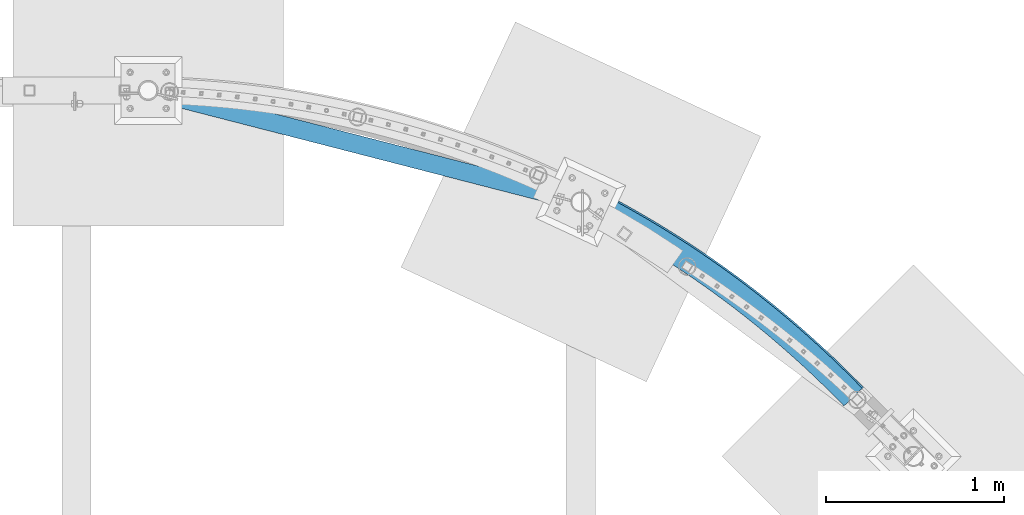
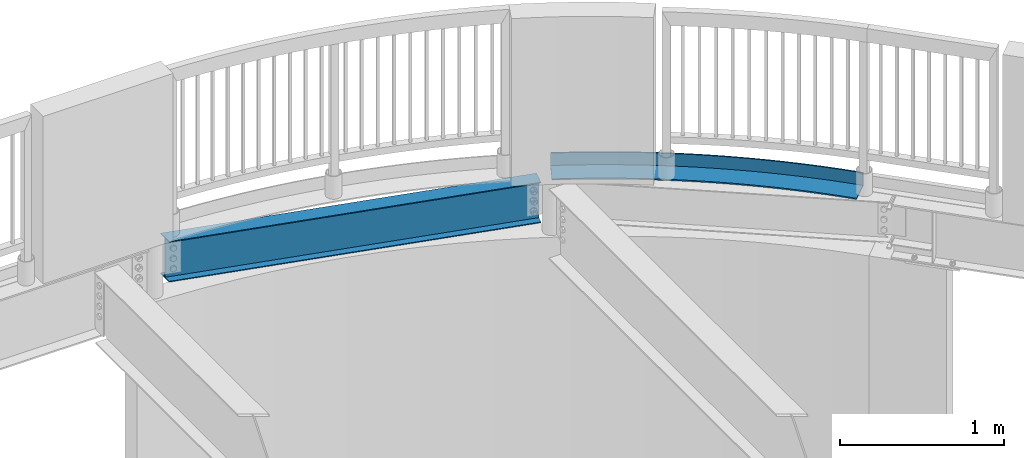
# One storey, part 329 of 975: 2 beams.
"""IFC2X3 building model written with IfcOpenShell, lengths in millimetres."""

from ifc_helpers import new_model, si_unit, frame, origin_with_axes, place, context, subcontext, project, spatial, faceted_brep, material, type_object, element, save


model = new_model("IFC2X3")

# Units and contexts
model_context = context("Model", 3, precision=1e-05, world=origin_with_axes())
body_context = subcontext(model_context, "Body", "Model", "MODEL_VIEW")
ifc_project = project(units=[si_unit("LENGTHUNIT", "METRE", prefix="MILLI"), si_unit("AREAUNIT", "SQUARE_METRE"), si_unit("VOLUMEUNIT", "CUBIC_METRE"), si_unit("MASSUNIT", "GRAM", prefix="KILO"), si_unit("TIMEUNIT", "SECOND"), si_unit("PLANEANGLEUNIT", "RADIAN"), si_unit("SOLIDANGLEUNIT", "STERADIAN"), si_unit("THERMODYNAMICTEMPERATUREUNIT", "DEGREE_CELSIUS"), si_unit("LUMINOUSINTENSITYUNIT", "LUMEN")], contexts=[model_context])

# Site, building, storey
site_placement = place(None, origin_with_axes())
site = spatial("IfcSite", under=ifc_project, at=site_placement, CompositionType="ELEMENT")
building_placement = place(site_placement, origin_with_axes())
building = spatial("IfcBuilding", under=site, at=building_placement, Name="Undefined", CompositionType="ELEMENT")
storey_placement = place(building_placement, origin_with_axes())
storey = spatial("IfcBuildingStorey", under=building, at=storey_placement, Name="Undefined", CompositionType="ELEMENT", Elevation=0.0)

# Beams
ifc_material_1 = material(Name="STEEL/A36")
beam_type_1 = type_object("IfcBeamType", Name="L6X4X3/8", PredefinedType="NOTDEFINED")
beam_1_placement = place(storey_placement, frame((20394.9391739001, 28239.6693829662, 3987.8), z_axis=(-0.592160376867189, -0.805820133819271, 0.0), x_axis=(-0.805820133819271, 0.592160376867189, 0.0)))
element("IfcBeam", 1, at=beam_1_placement, inside=storey, type_object=beam_type_1, material=ifc_material_1, Name="ANGLE", ObjectType="L6X4X3/8", context=body_context, shape_type="Brep", body=[
    faceted_brep([(12.7670494130856, 50.8000000000002, 75.1228490493304), (12.7670494130856, 41.2750000000001, 75.1228490493304), (44.1095823313375, 41.2750000000001, 69.8881844457283), (44.1095823313375, 50.8000000000002, 69.8881844457283), (-11.171168236449, 41.2750000000001, -65.7324929181559), (-11.171168236449, -50.8000000000002, -65.7324929181559), (20.9755353170134, -50.8000000000002, -71.1014658614949), (20.9755353170134, 41.2750000000001, -71.1014658614949), (-12.7670494130886, -50.8000000000002, -75.1228490493231), (-12.7670494130886, 50.8000000000002, -75.1228490493231), (19.4332655160564, 50.8000000000002, -80.5007758819775), (19.4332655160564, -50.8000000000002, -80.5007758819775), (75.481476174013, 41.2750000000001, 64.8324589816693), (75.481476174013, 50.8000000000002, 64.8324589816693), (53.1523531224396, -50.8000000000002, -76.286908536611), (53.1523531224396, 41.2750000000001, -76.286908536611), (51.6637449190006, 50.8000000000002, -85.6948663711664), (51.6637449190006, -50.8000000000002, -85.6948663711664), (106.881709359738, 41.2750000000001, 59.95583728973), (106.881709359738, 50.8000000000002, 59.95583728973), (85.3582373872399, -50.8000000000002, -81.2886520868924), (85.3582373872399, 41.2750000000001, -81.2886520868924), (83.923339255742, 50.8000000000002, -90.7049513786696), (83.923339255742, -50.8000000000002, -90.7049513786696), (138.309259384294, 41.2750000000001, 55.2584781701808), (138.309259384294, 50.8000000000002, 55.2584781701808), (117.592139372321, -50.8000000000002, -86.1065336376269), (117.592139372321, 41.2750000000001, -86.1065336376269), (116.210998038189, 50.8000000000002, -95.5308677581488), (116.210998038189, -50.8000000000002, -95.5308677581488), (169.763102853944, 41.2750000000001, 50.7405345859006), (169.763102853944, 50.8000000000002, 50.7405345859006), (149.853009426219, -50.8000000000002, -90.740396301313), (149.853009426219, 41.2750000000001, -90.740396301313), (148.52566986437, 50.8000000000002, -100.172458360466), (148.52566986437, -50.8000000000002, -100.172458360466), (201.242215518733, 41.2750000000001, 46.40215365732), (201.242215518733, 50.8000000000002, 46.40215365732), (182.139797019309, -50.8000000000002, -95.1900891827681), (182.139797019309, 41.2750000000001, -95.1900891827681), (180.866302452685, 50.8000000000002, -104.629572038779), (180.866302452685, -50.8000000000002, -104.629572038779), (232.745572305856, 41.2750000000001, 42.2434766576844), (232.745572305856, 50.8000000000002, 42.2434766576844), (214.451450777988, -50.8000000000002, -99.4554673840248), (214.451450777988, 41.2750000000001, -99.4554673840248), (213.231842676131, 50.8000000000002, -108.902063653477), (213.231842676131, -50.8000000000002, -108.902063653477), (264.272147353028, 41.2750000000001, 38.264639008441), (264.272147353028, 50.8000000000002, 38.264639008441), (246.786918518923, -50.8000000000002, -103.536392009082), (246.786918518923, 41.2750000000001, -103.536392009082), (245.621236596652, 50.8000000000002, -112.989794076922), (245.621236596652, -50.8000000000002, -112.989794076922), (295.820914041897, 41.2750000000001, 34.4657702748082), (295.820914041897, 50.8000000000002, 34.4657702748082), (279.14514728332, -50.8000000000002, -107.432730168388), (279.14514728332, 41.2750000000001, -107.432730168388), (278.033429499414, 50.8000000000002, -116.89263019793), (278.033429499414, -50.8000000000002, -116.89263019793), (327.390845031467, 41.2750000000001, 30.8469941615695), (327.390845031467, 50.8000000000002, 30.8469941615695), (311.525083371191, -50.8000000000002, -111.144354983197), (311.525083371191, 41.2750000000001, -111.144354983197), (310.467365927174, 50.8000000000002, -120.610444926184), (310.467365927174, -50.8000000000002, -120.610444926184), (358.980912291565, 41.2750000000001, 27.4084285090721), (358.980912291565, 50.8000000000002, 27.4084285090721), (343.925672375688, -50.8000000000002, -114.671145589702), (343.925672375688, 41.2750000000001, -114.671145589702), (342.921989714631, 50.8000000000002, -124.14311719629), (342.921989714631, -50.8000000000002, -124.14311719629), (390.590087136296, 41.2750000000001, 24.1501852893271), (390.590087136296, 50.8000000000002, 24.1501852893271), (376.345859217431, -50.8000000000002, -118.012987142953), (376.345859217431, 41.2750000000001, -118.012987142953), (375.396244022843, 50.8000000000002, -127.490531971765), (375.396244022843, -50.8000000000002, -127.490531971765), (422.217340257574, 41.2750000000001, 21.0723706024291), (422.217340257574, 50.8000000000002, 21.0723706024291), (408.784588178866, -50.8000000000002, -121.16977082059), (408.784588178866, 41.2750000000001, -121.16977082059), (407.889071373613, 50.8000000000002, -130.652580248789), (407.889071373613, -50.8000000000002, -130.652580248789), (453.861641758597, 41.2750000000001, 18.1750846730574), (453.861641758597, 50.8000000000002, 18.1750846730574), (441.240802938625, -50.8000000000002, -124.141393826423), (441.240802938625, 41.2750000000001, -124.141393826423), (440.399413683958, 50.8000000000002, -133.629159059725), (440.399413683958, -50.8000000000002, -133.629159059725), (485.521961187415, 41.2750000000001, 15.4584218472373), (485.521961187415, 50.8000000000002, 15.4584218472373), (473.713446605962, -50.8000000000002, -126.927759393751), (473.713446605962, 41.2750000000001, -126.927759393751), (472.926212300529, 50.8000000000002, -136.420171476486), (472.926212300529, -50.8000000000002, -136.420171476486), (517.19726757048, 41.2750000000001, 12.9224705892557), (517.19726757048, 50.8000000000002, 12.9224705892557), (506.201461755131, -50.8000000000002, -129.528776788524), (506.201461755131, 41.2750000000001, -129.528776788524), (505.468408034107, 50.8000000000002, -139.025526613703), (505.468408034107, -50.8000000000002, -139.025526613703), (548.886529446218, 41.2750000000001, 10.5673134787794), (548.886529446218, 50.8000000000002, 10.5673134787794), (538.703790459842, -50.8000000000002, -131.944361312264), (538.703790459842, 41.2750000000001, -131.944361312264), (538.024941194084, 50.8000000000002, -141.445139631673), (538.024941194084, -50.8000000000002, -141.445139631673), (580.588714898601, 41.2750000000001, 8.3930272081634), (580.588714898601, 50.8000000000002, 8.3930272081634), (571.219374327708, -50.8000000000002, -134.174434304899), (571.219374327708, 41.2750000000001, -134.174434304899), (570.594751622979, 50.8000000000002, -143.678931739109), (570.594751622979, -50.8000000000002, -143.678931739109), (612.302791590779, 41.2750000000001, 6.3996825799768), (612.302791590779, 50.8000000000002, 6.3996825799768), (603.747154534695, -50.8000000000002, -136.218923147251), (603.747154534695, 41.2750000000001, -136.218923147251), (603.176778730951, 50.8000000000002, -145.72683019573), (603.176778730951, -50.8000000000002, -145.72683019573), (644.027726798668, 41.2750000000001, 4.58734450466), (644.027726798668, 50.8000000000002, 4.58734450466), (636.286071859619, -50.8000000000002, -138.077761263419), (636.286071859619, 41.2750000000001, -138.077761263419), (635.76996153035, 50.8000000000002, -147.588768314621), (635.76996153035, -50.8000000000002, -147.588768314621), (675.7624874446, 41.2750000000001, 2.95607199845108), (675.7624874446, 50.8000000000002, 2.95607199845108), (668.835066718635, -50.8000000000002, -139.750888122973), (668.835066718635, 41.2750000000001, -139.750888122973), (668.373238670242, 50.8000000000002, -149.264685464404), (668.373238670242, -50.8000000000002, -149.264685464404), (707.50604013095, 41.2750000000001, 1.50591818142129), (707.50604013095, 50.8000000000002, 1.50591818142129), (701.393079199736, -50.8000000000002, -141.23824924291), (701.393079199736, 41.2750000000001, -141.23824924291), (700.985548470992, 50.8000000000002, -150.7545270712), (700.985548470992, -50.8000000000002, -150.7545270712), (739.25735117379, 41.2750000000001, 0.236930275794293), (739.25735117379, 50.8000000000002, 0.236930275794293), (733.959049097266, -50.8000000000002, -142.539796189405), (733.959049097266, 41.2750000000001, -142.539796189405), (733.605828958831, 50.8000000000002, -152.058244620421), (733.605828958831, -50.8000000000002, -152.058244620421), (771.015386636566, 41.2750000000001, -0.850850395640009), (771.015386636566, 50.8000000000002, -0.850850395640009), (766.531915946442, -50.8000000000002, -143.655486579424), (766.531915946442, 41.2750000000001, -143.655486579424), (766.233017900433, 50.8000000000002, -153.175795658346), (766.233017900433, -50.8000000000002, -153.175795658346), (802.77911236374, 41.2750000000001, -1.75738841084967), (802.77911236374, 50.8000000000002, -1.75738841084967), (799.110619057902, -50.8000000000002, -144.585284082095), (799.110619057902, 41.2750000000001, -144.585284082095), (798.866052837512, 50.8000000000002, -154.107143793517), (798.866052837512, -50.8000000000002, -154.107143793517), (834.547494014478, 41.2750000000001, -2.48265424968849), (834.547494014478, 50.8000000000002, -2.48265424968849), (831.694097552225, -50.8000000000002, -145.329158419874), (831.694097552225, 41.2750000000001, -145.329158419874), (831.50387112141, 50.8000000000002, -154.852258697887), (831.50387112141, -50.8000000000002, -154.852258697887), (866.319497096344, 41.2750000000001, -3.02662429491465), (866.319497096344, 50.8000000000002, -3.02662429491465), (864.281290394493, -50.8000000000002, -145.887085369533), (864.281290394493, 41.2750000000001, -145.887085369533), (864.145409947704, 50.8000000000002, -155.411116107847), (864.145409947704, -50.8000000000002, -155.411116107847), (898.094086998959, 41.2750000000001, -3.38928083289647), (898.094086998959, 50.8000000000002, -3.38928083289647), (896.871136428841, -50.8000000000002, -146.259046762985), (896.871136428841, 41.2750000000001, -146.259046762985), (896.789606390832, 50.8000000000002, -155.783697824991), (896.789606390832, -50.8000000000002, -155.783697824991), (929.870229027725, 41.2750000000001, -3.57061205425998), (929.870229027725, 50.8000000000002, -3.57061205425998), (929.46257441299, -50.8000000000002, -146.445030487819), (929.46257441299, 41.2750000000001, -146.445030487819), (929.435397438676, 50.8000000000002, -155.969991716724), (929.435397438676, -50.8000000000002, -155.969991716724), (961.646888437488, 41.2750000000001, -3.5706120541945), (961.646888437488, 50.8000000000002, -3.5706120541945), (962.054543052835, -50.8000000000002, -146.445030487754), (962.054543052835, 41.2750000000001, -146.445030487754), (962.081720027191, 50.8000000000002, -155.969991716658), (962.081720027191, -50.8000000000002, -155.969991716658), (993.423030466247, 41.2750000000001, -3.38928083269275), (993.423030466247, 50.8000000000002, -3.38928083269275), (994.645981036984, -50.8000000000002, -146.259046762767), (994.645981036984, 41.2750000000001, -146.259046762767), (994.727511075035, 50.8000000000002, -155.78369782478), (994.727511075035, -50.8000000000002, -155.78369782478), (1025.19762036887, 41.2750000000001, -3.02662429457268), (1025.19762036887, 50.8000000000002, -3.02662429457268), (1027.23582707133, -50.8000000000002, -145.887085369184), (1027.23582707133, 41.2750000000001, -145.887085369184), (1027.37170751816, 50.8000000000002, -155.411116107491), (1027.37170751816, -50.8000000000002, -155.411116107491), (1056.96962345073, 41.2750000000001, -2.48265424920828), (1056.96962345073, 50.8000000000002, -2.48265424920828), (1059.82301991359, -50.8000000000002, -145.329158419379), (1059.82301991359, 41.2750000000001, -145.329158419379), (1060.01324634446, 50.8000000000002, -154.852258697392), (1060.01324634446, -50.8000000000002, -154.852258697392), (1088.73800510146, 41.2750000000001, -1.75738841022394), (1088.73800510146, 50.8000000000002, -1.75738841022394), (1092.40649840792, -50.8000000000002, -144.58528408147), (1092.40649840792, 41.2750000000001, -144.58528408147), (1092.65106462835, 50.8000000000002, -154.107143792884), (1092.65106462835, -50.8000000000002, -154.107143792884), (1120.50173082863, 41.2750000000001, -0.850850394890585), (1120.50173082863, 50.8000000000002, -0.850850394890585), (1124.98520151937, -50.8000000000002, -143.655486578653), (1124.98520151937, 41.2750000000001, -143.655486578653), (1125.28409956542, 50.8000000000002, -153.175795657575), (1125.28409956542, -50.8000000000002, -153.175795657575), (1152.2597662914, 41.2750000000001, 0.23693027668196), (1152.2597662914, 50.8000000000002, 0.23693027668196), (1157.55806836854, -50.8000000000002, -142.539796188496), (1157.55806836854, 41.2750000000001, -142.539796188496), (1157.91128850702, 50.8000000000002, -152.058244619504), (1157.91128850702, -50.8000000000002, -152.058244619504), (1184.01107733424, 41.2750000000001, 1.50591818245448), (1184.01107733424, 50.8000000000002, 1.50591818245448), (1190.12403826606, -50.8000000000002, -141.238249241862), (1190.12403826606, 41.2750000000001, -141.238249241862), (1190.53156899486, 50.8000000000002, -150.754527070145), (1190.53156899486, -50.8000000000002, -150.754527070145), (1215.75463002058, 41.2750000000001, 2.95607199961523), (1215.75463002058, 50.8000000000002, 2.95607199961523), (1222.68205074716, -50.8000000000002, -139.750888121787), (1222.68205074716, 41.2750000000001, -139.750888121787), (1223.14387879559, 50.8000000000002, -149.264685463211), (1223.14387879559, -50.8000000000002, -149.264685463211), (1247.4893906665, 41.2750000000001, 4.58734450596239), (1247.4893906665, 50.8000000000002, 4.58734450596239), (1255.23104560617, -50.8000000000002, -138.07776126208), (1255.23104560617, 41.2750000000001, -138.07776126208), (1255.74715593548, 50.8000000000002, -147.58876831329), (1255.74715593548, -50.8000000000002, -147.58876831329), (1279.21432587439, 41.2750000000001, 6.39968258141744), (1279.21432587439, 50.8000000000002, 6.39968258141744), (1287.76996293109, -50.8000000000002, -136.218923145774), (1287.76996293109, 41.2750000000001, -136.218923145774), (1288.34033873487, 50.8000000000002, -145.72683019426), (1288.34033873487, -50.8000000000002, -145.72683019426), (1310.92840256655, 41.2750000000001, 8.39302720974229), (1310.92840256655, 50.8000000000002, 8.39302720974229), (1320.29774313806, -50.8000000000002, -134.174434303291), (1320.29774313806, 41.2750000000001, -134.174434303291), (1320.92236584284, 50.8000000000002, -143.678931737486), (1320.92236584284, -50.8000000000002, -143.678931737486), (1342.63058801893, 41.2750000000001, 10.5673134804892), (1342.63058801893, 50.8000000000002, 10.5673134804892), (1352.81332700592, -50.8000000000002, -131.94436131051), (1352.81332700592, 41.2750000000001, -131.94436131051), (1353.49217627172, 50.8000000000002, -141.445139629912), (1353.49217627172, -50.8000000000002, -141.445139629912), (1374.31984989466, 41.2750000000001, 12.9224705911038), (1374.31984989466, 50.8000000000002, 12.9224705911038), (1385.31565571063, -50.8000000000002, -129.528776786625), (1385.31565571063, 41.2750000000001, -129.528776786625), (1386.04870943168, 50.8000000000002, -139.025526611804), (1386.04870943168, -50.8000000000002, -139.025526611804), (1405.99515627771, 41.2750000000001, 15.4584218492237), (1405.99515627771, 50.8000000000002, 15.4584218492237), (1417.80367085978, -50.8000000000002, -126.927759391714), (1417.80367085978, 41.2750000000001, -126.927759391714), (1418.59090516525, 50.8000000000002, -136.420171474449), (1418.59090516525, -50.8000000000002, -136.420171474449), (1437.65547570652, 41.2750000000001, 18.175084675182), (1437.65547570652, 50.8000000000002, 18.175084675182), (1450.2763145271, -50.8000000000002, -124.141393824248), (1450.2763145271, 41.2750000000001, -124.141393824248), (1451.11770378181, 50.8000000000002, -133.629159057542), (1451.11770378181, -50.8000000000002, -133.629159057542), (1469.29977720753, 41.2750000000001, 21.0723706046847), (1469.29977720753, 50.8000000000002, 21.0723706046847), (1482.73252928685, -50.8000000000002, -121.169770818269), (1482.73252928685, 41.2750000000001, -121.169770818269), (1483.62804609214, 50.8000000000002, -130.652580246468), (1483.62804609214, -50.8000000000002, -130.652580246468), (1500.92703032879, 41.2750000000001, 24.1501852917208), (1500.92703032879, 50.8000000000002, 24.1501852917208), (1515.17125824827, -50.8000000000002, -118.012987140493), (1515.17125824827, 41.2750000000001, -118.012987140493), (1516.1208734429, 50.8000000000002, -127.490531969306), (1516.1208734429, -50.8000000000002, -127.490531969306), (1532.53620517351, 41.2750000000001, 27.4084285116041), (1532.53620517351, 50.8000000000002, 27.4084285116041), (1547.59144509, -50.8000000000002, -114.671145587105), (1547.59144509, 41.2750000000001, -114.671145587105), (1548.59512775109, 50.8000000000002, -124.143117193693), (1548.59512775109, -50.8000000000002, -124.143117193693), (1564.12627243359, 41.2750000000001, 30.8469941642397), (1564.12627243359, 50.8000000000002, 30.8469941642397), (1579.99203409448, -50.8000000000002, -111.144354980461), (1579.99203409448, 41.2750000000001, -111.144354980461), (1581.04975153854, 50.8000000000002, -120.610444923441), (1581.04975153854, -50.8000000000002, -120.610444923441), (1595.69620342315, 41.2750000000001, 34.4657702776094), (1595.69620342315, 50.8000000000002, 34.4657702776094), (1612.37197018234, -50.8000000000002, -107.432730165514), (1612.37197018234, 41.2750000000001, -107.432730165514), (1613.48368796628, 50.8000000000002, -116.892630195049), (1613.48368796628, -50.8000000000002, -116.892630195049), (1627.244970112, 41.2750000000001, 38.2646390113805), (1627.244970112, 50.8000000000002, 38.2646390113805), (1644.73019894672, -50.8000000000002, -103.53639200607), (1644.73019894672, 41.2750000000001, -103.53639200607), (1645.89588086903, 50.8000000000002, -112.989794073896), (1645.89588086903, -50.8000000000002, -112.989794073896), (1658.77154515916, 41.2750000000001, 42.2434766607621), (1658.77154515916, 50.8000000000002, 42.2434766607621), (1677.06566668764, -50.8000000000002, -99.4554673808743), (1677.06566668764, 41.2750000000001, -99.4554673808743), (1678.28527478953, 50.8000000000002, -108.902063650319), (1678.28527478953, -50.8000000000002, -108.902063650319), (1690.27490194626, 41.2750000000001, 46.4021536605287), (1690.27490194626, 50.8000000000002, 46.4021536605287), (1709.37732044629, -50.8000000000002, -95.1900891794794), (1709.37732044629, 41.2750000000001, -95.1900891794794), (1710.65081501296, 50.8000000000002, -104.629572035476), (1710.65081501296, -50.8000000000002, -104.629572035476), (1721.75401461103, 41.2750000000001, 50.7405345892475), (1721.75401461103, 50.8000000000002, 50.7405345892475), (1741.66410803937, -50.8000000000002, -90.740396297886), (1741.66410803937, 41.2750000000001, -90.740396297886), (1742.99144760125, 50.8000000000002, -100.172458357025), (1742.99144760125, -50.8000000000002, -100.172458357025), (1753.20785808066, 41.2750000000001, 55.2584781736659), (1753.20785808066, 50.8000000000002, 55.2584781736659), (1773.92497809325, -50.8000000000002, -86.1065336340544), (1773.92497809325, 41.2750000000001, -86.1065336340544), (1775.30611942742, 50.8000000000002, -95.530867754569), (1775.30611942742, -50.8000000000002, -95.530867754569), (1784.6354081052, 41.2750000000001, 59.9558372933461), (1784.6354081052, 50.8000000000002, 59.9558372933461), (1806.1588800783, -50.8000000000002, -81.2886520831817), (1806.1588800783, 41.2750000000001, -81.2886520831817), (1807.59377820984, 50.8000000000002, -90.7049513749516), (1807.59377820984, -50.8000000000002, -90.7049513749516), (1816.0356412909, 41.2750000000001, 64.8324589854237), (1816.0356412909, 50.8000000000002, 64.8324589854237), (1838.36476434308, -50.8000000000002, -76.286908532762), (1838.36476434308, 41.2750000000001, -76.286908532762), (1839.85337254656, 50.8000000000002, -85.6948663673102), (1839.85337254656, -50.8000000000002, -85.6948663673102), (1847.40753513355, 41.2750000000001, 69.8881844496136), (1847.40753513355, 50.8000000000002, 69.8881844496136), (1870.54158214849, -50.8000000000002, -71.1014658575077), (1870.54158214849, 41.2750000000001, -71.1014658575077), (1872.08385194949, 50.8000000000002, -80.500775877983), (1872.08385194949, -50.8000000000002, -80.500775877983), (1878.75006805179, 50.8000000000002, 75.122849053354), (1904.2841668786, 50.8000000000002, -75.1228490451831), (1878.75006805179, 41.2750000000001, 75.122849053354), (1902.68828570193, 41.2750000000001, -65.7324929140304), (1902.68828570193, -50.8000000000002, -65.7324929140304), (1904.2841668786, -50.8000000000002, -75.1228490451831)], [[[0, 1, 2, 3]], [[4, 5, 6, 7]], [[8, 9, 10, 11]], [[8, 5, 4, 1, 0, 9]], [[3, 2, 12, 13]], [[7, 6, 14, 15]], [[11, 10, 16, 17]], [[13, 12, 18, 19]], [[15, 14, 20, 21]], [[17, 16, 22, 23]], [[19, 18, 24, 25]], [[21, 20, 26, 27]], [[23, 22, 28, 29]], [[25, 24, 30, 31]], [[27, 26, 32, 33]], [[29, 28, 34, 35]], [[31, 30, 36, 37]], [[33, 32, 38, 39]], [[35, 34, 40, 41]], [[37, 36, 42, 43]], [[39, 38, 44, 45]], [[41, 40, 46, 47]], [[43, 42, 48, 49]], [[45, 44, 50, 51]], [[47, 46, 52, 53]], [[49, 48, 54, 55]], [[51, 50, 56, 57]], [[53, 52, 58, 59]], [[55, 54, 60, 61]], [[57, 56, 62, 63]], [[59, 58, 64, 65]], [[61, 60, 66, 67]], [[63, 62, 68, 69]], [[65, 64, 70, 71]], [[67, 66, 72, 73]], [[69, 68, 74, 75]], [[71, 70, 76, 77]], [[73, 72, 78, 79]], [[75, 74, 80, 81]], [[77, 76, 82, 83]], [[79, 78, 84, 85]], [[81, 80, 86, 87]], [[83, 82, 88, 89]], [[85, 84, 90, 91]], [[87, 86, 92, 93]], [[89, 88, 94, 95]], [[91, 90, 96, 97]], [[93, 92, 98, 99]], [[95, 94, 100, 101]], [[97, 96, 102, 103]], [[99, 98, 104, 105]], [[101, 100, 106, 107]], [[103, 102, 108, 109]], [[105, 104, 110, 111]], [[107, 106, 112, 113]], [[109, 108, 114, 115]], [[111, 110, 116, 117]], [[113, 112, 118, 119]], [[115, 114, 120, 121]], [[117, 116, 122, 123]], [[119, 118, 124, 125]], [[121, 120, 126, 127]], [[123, 122, 128, 129]], [[125, 124, 130, 131]], [[127, 126, 132, 133]], [[129, 128, 134, 135]], [[131, 130, 136, 137]], [[133, 132, 138, 139]], [[135, 134, 140, 141]], [[137, 136, 142, 143]], [[139, 138, 144, 145]], [[141, 140, 146, 147]], [[143, 142, 148, 149]], [[145, 144, 150, 151]], [[147, 146, 152, 153]], [[149, 148, 154, 155]], [[151, 150, 156, 157]], [[153, 152, 158, 159]], [[155, 154, 160, 161]], [[157, 156, 162, 163]], [[159, 158, 164, 165]], [[161, 160, 166, 167]], [[163, 162, 168, 169]], [[165, 164, 170, 171]], [[167, 166, 172, 173]], [[169, 168, 174, 175]], [[171, 170, 176, 177]], [[173, 172, 178, 179]], [[175, 174, 180, 181]], [[177, 176, 182, 183]], [[179, 178, 184, 185]], [[181, 180, 186, 187]], [[183, 182, 188, 189]], [[185, 184, 190, 191]], [[187, 186, 192, 193]], [[189, 188, 194, 195]], [[191, 190, 196, 197]], [[193, 192, 198, 199]], [[195, 194, 200, 201]], [[197, 196, 202, 203]], [[199, 198, 204, 205]], [[201, 200, 206, 207]], [[203, 202, 208, 209]], [[205, 204, 210, 211]], [[207, 206, 212, 213]], [[209, 208, 214, 215]], [[211, 210, 216, 217]], [[213, 212, 218, 219]], [[215, 214, 220, 221]], [[217, 216, 222, 223]], [[219, 218, 224, 225]], [[221, 220, 226, 227]], [[223, 222, 228, 229]], [[225, 224, 230, 231]], [[227, 226, 232, 233]], [[229, 228, 234, 235]], [[231, 230, 236, 237]], [[233, 232, 238, 239]], [[235, 234, 240, 241]], [[237, 236, 242, 243]], [[239, 238, 244, 245]], [[241, 240, 246, 247]], [[243, 242, 248, 249]], [[245, 244, 250, 251]], [[247, 246, 252, 253]], [[249, 248, 254, 255]], [[251, 250, 256, 257]], [[253, 252, 258, 259]], [[255, 254, 260, 261]], [[257, 256, 262, 263]], [[259, 258, 264, 265]], [[261, 260, 266, 267]], [[263, 262, 268, 269]], [[265, 264, 270, 271]], [[267, 266, 272, 273]], [[269, 268, 274, 275]], [[271, 270, 276, 277]], [[273, 272, 278, 279]], [[275, 274, 280, 281]], [[277, 276, 282, 283]], [[279, 278, 284, 285]], [[281, 280, 286, 287]], [[283, 282, 288, 289]], [[285, 284, 290, 291]], [[287, 286, 292, 293]], [[289, 288, 294, 295]], [[291, 290, 296, 297]], [[293, 292, 298, 299]], [[295, 294, 300, 301]], [[297, 296, 302, 303]], [[299, 298, 304, 305]], [[301, 300, 306, 307]], [[303, 302, 308, 309]], [[305, 304, 310, 311]], [[307, 306, 312, 313]], [[309, 308, 314, 315]], [[311, 310, 316, 317]], [[313, 312, 318, 319]], [[315, 314, 320, 321]], [[317, 316, 322, 323]], [[319, 318, 324, 325]], [[321, 320, 326, 327]], [[323, 322, 328, 329]], [[325, 324, 330, 331]], [[327, 326, 332, 333]], [[329, 328, 334, 335]], [[331, 330, 336, 337]], [[333, 332, 338, 339]], [[335, 334, 340, 341]], [[337, 336, 342, 343]], [[339, 338, 344, 345]], [[341, 340, 346, 347]], [[343, 342, 348, 349]], [[345, 344, 350, 351]], [[347, 346, 352, 353]], [[352, 346, 340, 334, 328, 322, 316, 310, 304, 298, 292, 286, 280, 274, 268, 262, 256, 250, 244, 238, 232, 226, 220, 214, 208, 202, 196, 190, 184, 178, 172, 166, 160, 154, 148, 142, 136, 130, 124, 118, 112, 106, 100, 94, 88, 82, 76, 70, 64, 58, 52, 46, 40, 34, 28, 22, 16, 10, 9, 0, 3, 13, 19, 25, 31, 37, 43, 49, 55, 61, 67, 73, 79, 85, 91, 97, 103, 109, 115, 121, 127, 133, 139, 145, 151, 157, 163, 169, 175, 181, 187, 193, 199, 205, 211, 217, 223, 229, 235, 241, 247, 253, 259, 265, 271, 277, 283, 289, 295, 301, 307, 313, 319, 325, 331, 337, 343, 349, 354, 355]], [[349, 348, 356, 354]], [[348, 342, 336, 330, 324, 318, 312, 306, 300, 294, 288, 282, 276, 270, 264, 258, 252, 246, 240, 234, 228, 222, 216, 210, 204, 198, 192, 186, 180, 174, 168, 162, 156, 150, 144, 138, 132, 126, 120, 114, 108, 102, 96, 90, 84, 78, 72, 66, 60, 54, 48, 42, 36, 30, 24, 18, 12, 2, 1, 4, 7, 15, 21, 27, 33, 39, 45, 51, 57, 63, 69, 75, 81, 87, 93, 99, 105, 111, 117, 123, 129, 135, 141, 147, 153, 159, 165, 171, 177, 183, 189, 195, 201, 207, 213, 219, 225, 231, 237, 243, 249, 255, 261, 267, 273, 279, 285, 291, 297, 303, 309, 315, 321, 327, 333, 339, 345, 351, 357, 356]], [[351, 350, 358, 357]], [[350, 344, 338, 332, 326, 320, 314, 308, 302, 296, 290, 284, 278, 272, 266, 260, 254, 248, 242, 236, 230, 224, 218, 212, 206, 200, 194, 188, 182, 176, 170, 164, 158, 152, 146, 140, 134, 128, 122, 116, 110, 104, 98, 92, 86, 80, 74, 68, 62, 56, 50, 44, 38, 32, 26, 20, 14, 6, 5, 8, 11, 17, 23, 29, 35, 41, 47, 53, 59, 65, 71, 77, 83, 89, 95, 101, 107, 113, 119, 125, 131, 137, 143, 149, 155, 161, 167, 173, 179, 185, 191, 197, 203, 209, 215, 221, 227, 233, 239, 245, 251, 257, 263, 269, 275, 281, 287, 293, 299, 305, 311, 317, 323, 329, 335, 341, 347, 353, 359, 358]], [[353, 352, 355, 359]], [[356, 357, 358, 359, 355, 354]]]),
])
ifc_material_2 = material(Name="STEEL/A992")
beam_type_2 = type_object("IfcBeamType", Name="W12X14", PredefinedType="NOTDEFINED")
beam_2_placement = place(storey_placement, frame((16424.275, 29962.475, 3786.1875), z_axis=(0.0, 0.0, 1.0), x_axis=(0.968410220722009, -0.249362475928417, 0.0)))
element("IfcBeam", 2, at=beam_2_placement, inside=storey, type_object=beam_type_2, material=ifc_material_2, Name="BEAM", ObjectType="W12X14", context=body_context, shape_type="Brep", body=[
    faceted_brep([(85.20935860797, -50.8000000001193, -150.8125), (59.0476897075368, 50.7999999998719, -150.8125), (2434.15063476969, 50.799999995812, -150.8125), (2434.1506347697, -50.8000000041357, -150.8125), (85.20935860797, -50.8000000001193, -144.4625), (72.7416882726084, -2.38125000012224, -144.4625), (72.7416882726084, -2.38125000012224, 144.4625), (85.20935860797, -50.8000000001193, 144.4625), (85.20935860797, -50.8000000001193, 150.8125), (59.0476897075368, 50.7999999998719, 150.8125), (59.0476897075368, 50.7999999998719, 144.4625), (71.5153600428985, 2.38124999987485, 144.4625), (71.5153600428985, 2.38124999987485, -144.4625), (59.0476897075368, 50.7999999998719, -144.4625), (2434.1506347697, -50.8000000041357, -144.4625), (2434.15063476969, -2.38125000416039, -144.4625), (2434.15063476969, -2.38125000416039, 144.4625), (2434.1506347697, -50.8000000041357, 144.4625), (2434.1506347697, -50.8000000041357, 150.8125), (2434.15063476969, 50.799999995812, 150.8125), (2434.15063476969, 50.799999995812, 144.4625), (2434.1506347697, 2.38124999582942, 144.4625), (2434.1506347697, 2.38124999582942, -144.4625), (2434.15063476969, 50.799999995812, -144.4625)], [[[0, 1, 2, 3]], [[0, 4, 5, 6, 7, 8, 9, 10, 11, 12, 13, 1]], [[5, 4, 14, 15]], [[6, 5, 15, 16]], [[7, 6, 16, 17]], [[8, 7, 17, 18]], [[9, 8, 18, 19]], [[10, 9, 19, 20]], [[11, 10, 20, 21]], [[12, 11, 21, 22]], [[13, 12, 22, 23]], [[1, 13, 23, 2]], [[22, 21, 20, 19, 18, 17, 16, 15, 14, 3, 2, 23]], [[4, 0, 3, 14]]]),
])

save(model, "model.ifc")
